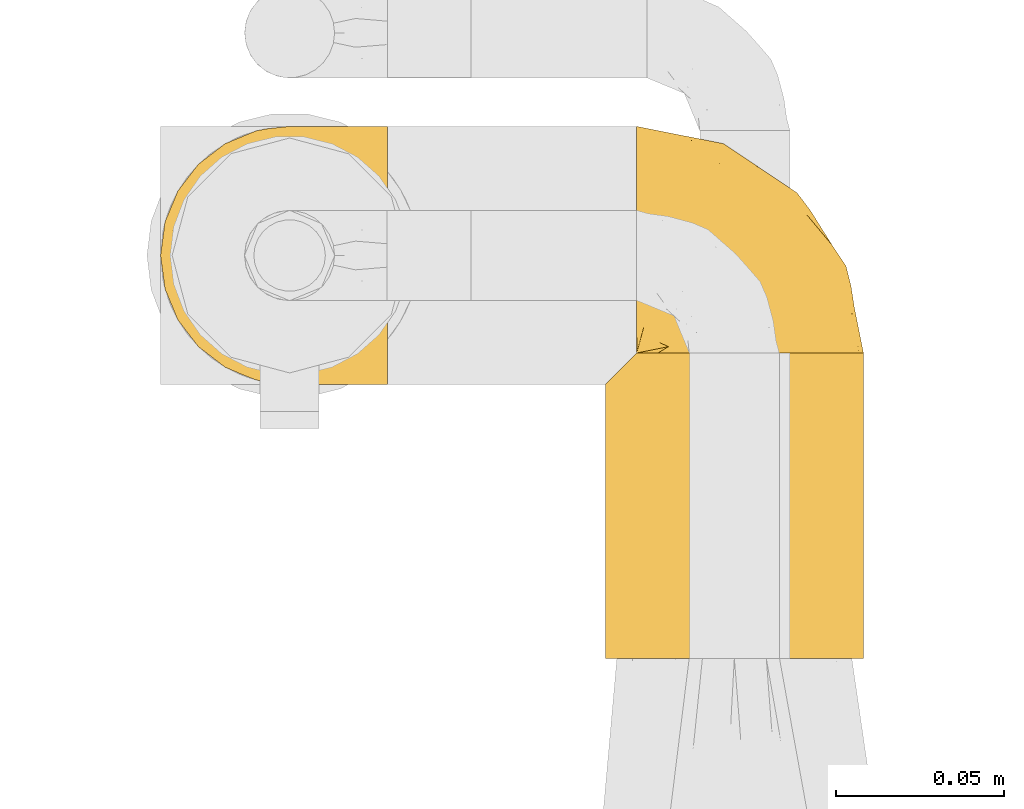
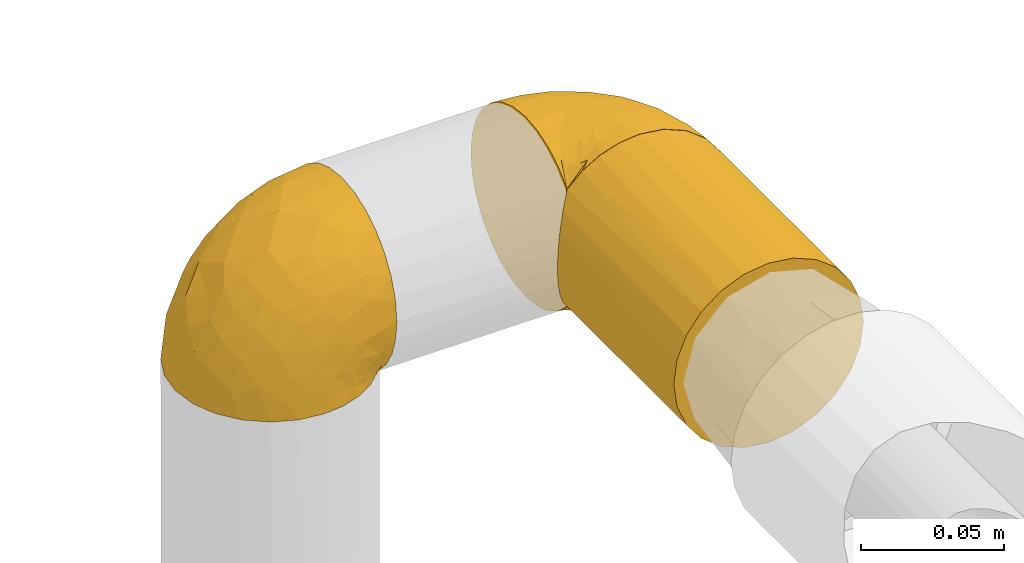
# One storey, part 66 of 827: 3 coverings.
"""IFC2X3 building model written with IfcOpenShell, lengths in millimetres."""

from ifc_helpers import new_model, entity, si_unit, converted_unit, derived_unit, direction, frame, origin, place, context, subcontext, project, spatial, faceted_brep, element, save


model = new_model("IFC2X3")

# Units and contexts
model_context = context("Model", 3, precision=0.01, world=origin(), true_north=direction((6.12303176911189e-17, 1.0)))
body_context = subcontext(model_context, "Body", "Model", "MODEL_VIEW")
ifc_project = project(units=[si_unit("LENGTHUNIT", "METRE", prefix="MILLI"), si_unit("AREAUNIT", "SQUARE_METRE"), si_unit("VOLUMEUNIT", "CUBIC_METRE"), converted_unit("PLANEANGLEUNIT", "DEGREE", entity("IfcRatioMeasure", 0.0174532925199433), si_unit("PLANEANGLEUNIT", "RADIAN"), dimensions=[0, 0, 0, 0, 0, 0, 0]), si_unit("MASSUNIT", "GRAM", prefix="KILO"), derived_unit("MASSDENSITYUNIT", [(si_unit("MASSUNIT", "GRAM", prefix="KILO"), 1), (si_unit("LENGTHUNIT", "METRE"), -3)]), derived_unit("MOMENTOFINERTIAUNIT", [(si_unit("LENGTHUNIT", "METRE"), 4)]), si_unit("TIMEUNIT", "SECOND"), si_unit("FREQUENCYUNIT", "HERTZ"), si_unit("THERMODYNAMICTEMPERATUREUNIT", "DEGREE_CELSIUS"), derived_unit("THERMALTRANSMITTANCEUNIT", [(si_unit("MASSUNIT", "GRAM", prefix="KILO"), 1), (si_unit("THERMODYNAMICTEMPERATUREUNIT", "KELVIN"), -1), (si_unit("TIMEUNIT", "SECOND"), -3)]), derived_unit("VOLUMETRICFLOWRATEUNIT", [(si_unit("LENGTHUNIT", "METRE"), 3), (si_unit("TIMEUNIT", "SECOND"), -1)]), derived_unit("MASSFLOWRATEUNIT", [(si_unit("MASSUNIT", "GRAM", prefix="KILO"), 1), (si_unit("TIMEUNIT", "SECOND"), -1)]), derived_unit("ROTATIONALFREQUENCYUNIT", [(si_unit("TIMEUNIT", "SECOND"), -1)]), si_unit("ELECTRICCURRENTUNIT", "AMPERE"), si_unit("ELECTRICVOLTAGEUNIT", "VOLT"), si_unit("POWERUNIT", "WATT"), si_unit("FORCEUNIT", "NEWTON", prefix="KILO"), si_unit("ILLUMINANCEUNIT", "LUX"), si_unit("LUMINOUSFLUXUNIT", "LUMEN"), si_unit("LUMINOUSINTENSITYUNIT", "CANDELA"), derived_unit("USERDEFINED", [(si_unit("MASSUNIT", "GRAM", prefix="KILO"), -1), (si_unit("LENGTHUNIT", "METRE"), -2), (si_unit("TIMEUNIT", "SECOND"), 3), (si_unit("LUMINOUSFLUXUNIT", "LUMEN"), 1)]), derived_unit("LINEARVELOCITYUNIT", [(si_unit("LENGTHUNIT", "METRE"), 1), (si_unit("TIMEUNIT", "SECOND"), -1)]), si_unit("PRESSUREUNIT", "PASCAL"), derived_unit("USERDEFINED", [(si_unit("LENGTHUNIT", "METRE"), -2), (si_unit("MASSUNIT", "GRAM", prefix="KILO"), 1), (si_unit("TIMEUNIT", "SECOND"), -2)]), derived_unit("LINEARFORCEUNIT", [(si_unit("MASSUNIT", "GRAM", prefix="KILO"), 1), (si_unit("LENGTHUNIT", "METRE"), 1), (si_unit("TIMEUNIT", "SECOND"), -2), (si_unit("LENGTHUNIT", "METRE"), -1)]), derived_unit("PLANARFORCEUNIT", [(si_unit("MASSUNIT", "GRAM", prefix="KILO"), 1), (si_unit("LENGTHUNIT", "METRE"), 1), (si_unit("TIMEUNIT", "SECOND"), -2), (si_unit("LENGTHUNIT", "METRE"), -2)])], contexts=[model_context])

# Site, building, storey
site_placement = place(None, origin())
site = spatial("IfcSite", under=ifc_project, at=site_placement, CompositionType="ELEMENT")
building_placement = place(site_placement, origin())
building = spatial("IfcBuilding", under=site, at=building_placement, CompositionType="ELEMENT")
storey_placement = place(building_placement, frame((0.0, 0.0, 28200.0)))
storey = spatial("IfcBuildingStorey", under=building, at=storey_placement, Name="08", CompositionType="ELEMENT", Elevation=28200.0)

# Coverings
covering_1_placement = place(storey_placement, frame((15026.93, 12139.38, 1515.05)))
element("IfcCovering", 1, at=covering_1_placement, inside=storey, Name=":ADSK_", ObjectType=":ADSK_", PredefinedType="INSULATION", context=body_context, shape_type="Brep", body=[
    faceted_brep([(69.15, 74.68, 47.38), (69.15, 70.1, 54.67), (69.15, 64.01, 60.76), (69.15, 56.72, 65.34), (69.15, 48.6, 68.18), (69.15, 40.05, 69.15), (69.15, 31.49, 68.18), (69.15, 23.36, 65.34), (69.15, 16.07, 60.75), (69.15, 9.98, 54.66), (69.15, 5.4, 47.37), (69.15, 2.56, 39.25), (69.15, 1.6, 30.7), (69.15, 2.46, 22.6), (69.15, 5.01, 14.86), (69.15, 9.13, 7.84), (69.15, 14.62, 1.85), (69.15, 16.82, 1.85), (69.15, 18.56, 1.85), (69.15, 20.52, 1.85), (69.15, 22.49, 1.85), (69.15, 24.46, 1.85), (69.15, 26.42, 1.85), (69.15, 28.39, 1.85), (69.15, 30.36, 1.85), (69.15, 32.55, 1.85), (69.15, 34.75, 1.85), (69.15, 36.94, 1.85), (69.15, 39.13, 1.85), (69.15, 41.33, 1.85), (69.15, 43.52, 1.85), (69.15, 45.72, 1.85), (69.15, 47.91, 1.85), (69.15, 50.11, 1.85), (69.15, 52.3, 1.85), (69.15, 54.49, 1.85), (69.15, 56.69, 1.85), (69.15, 58.88, 1.85), (69.15, 61.08, 1.85), (69.15, 63.27, 1.85), (69.15, 65.47, 1.85), (69.15, 70.97, 7.85), (69.15, 75.09, 14.88), (69.15, 77.64, 22.61), (69.15, 78.5, 30.7), (69.15, 77.53, 39.26), (68.89, 14.62, 1.6), (62.89, 9.12, 1.6), (55.87, 5.0, 1.6), (48.14, 2.46, 1.6), (40.05, 1.6, 1.6), (30.09, 2.91, 1.6), (20.82, 6.75, 1.6), (12.86, 12.86, 1.6), (6.75, 20.82, 1.6), (2.91, 30.09, 1.6), (1.6, 40.05, 1.6), (2.91, 50.0, 1.6), (6.75, 59.27, 1.6), (12.86, 67.23, 1.6), (20.82, 73.34, 1.6), (30.09, 77.19, 1.6), (40.05, 78.5, 1.6), (48.14, 77.63, 1.6), (55.87, 75.09, 1.6), (62.89, 70.97, 1.6), (68.89, 65.47, 1.6), (68.89, 63.27, 1.6), (68.89, 62.29, 1.6), (68.89, 60.7, 1.6), (68.89, 59.11, 1.6), (68.89, 57.52, 1.6), (68.89, 55.93, 1.6), (68.89, 54.34, 1.6), (68.89, 52.76, 1.6), (68.89, 51.17, 1.6), (68.89, 49.58, 1.6), (68.89, 47.99, 1.6), (68.89, 46.4, 1.6), (68.89, 44.81, 1.6), (68.89, 43.22, 1.6), (68.89, 41.63, 1.6), (68.89, 40.05, 1.6), (68.89, 38.46, 1.6), (68.89, 36.87, 1.6), (68.89, 35.28, 1.6), (68.89, 33.69, 1.6), (68.89, 32.1, 1.6), (68.89, 30.51, 1.6), (68.89, 28.92, 1.6), (68.89, 27.33, 1.6), (68.89, 25.37, 1.6), (68.89, 23.4, 1.6), (68.89, 21.21, 1.6), (68.89, 19.01, 1.6), (68.89, 16.82, 1.6), (68.97, 42.32, 1.78), (68.96, 44.02, 1.77), (68.97, 47.13, 1.78), (68.97, 48.74, 1.77), (68.98, 23.57, 1.79), (68.97, 25.13, 1.78), (68.96, 61.34, 1.76), (68.96, 22.02, 1.77), (68.96, 29.72, 1.77), (68.96, 56.73, 1.76), (68.96, 55.14, 1.77), (68.96, 37.66, 1.77), (69.0, 64.12, 1.8), (68.96, 28.13, 1.76), (68.96, 26.62, 1.77), (68.97, 31.46, 1.78), (68.96, 16.16, 1.77), (68.96, 39.16, 1.77), (68.96, 50.37, 1.76), (68.97, 17.69, 1.77), (68.97, 19.17, 1.78), (68.97, 62.78, 1.77), (68.96, 58.35, 1.77), (68.96, 45.53, 1.77), (68.97, 59.91, 1.78), (68.97, 65.47, 1.77), (69.02, 65.47, 1.8), (69.08, 65.47, 1.82), (68.97, 14.62, 1.77), (68.94, 14.62, 1.72), (68.92, 14.62, 1.66), (68.96, 20.59, 1.76), (68.96, 32.99, 1.77), (68.95, 34.48, 1.76), (68.96, 51.91, 1.77), (68.92, 65.47, 1.66), (68.94, 65.47, 1.72), (68.98, 53.48, 1.78), (69.08, 14.62, 1.82), (69.02, 14.62, 1.8), (68.96, 40.77, 1.77), (68.97, 35.97, 1.78), (61.33, 7.84, 3.72), (53.1, 3.53, 7.41), (63.33, 8.32, 6.13), (49.27, 1.6, 21.47), (55.53, 2.19, 19.34), (54.6, 1.6, 26.8), (41.99, 1.6, 8.87), (57.07, 4.57, 9.2), (57.95, 3.96, 12.79), (51.56, 2.28, 14.62), (41.58, 1.6, 7.34), (61.7, 7.69, 5.33), (63.33, 3.53, 17.64), (65.0, 8.32, 7.7), (67.02, 7.84, 9.41), (61.87, 1.6, 28.75), (43.94, 1.6, 16.15), (61.21, 4.34, 14.14), (63.4, 1.6, 29.16), (33.11, 29.63, 57.02), (52.82, 27.34, 64.92), (43.3, 40.05, 64.0), (33.73, 2.39, 11.92), (36.52, 2.43, 19.16), (24.87, 9.07, 28.65), (14.17, 16.64, 24.62), (18.43, 9.54, 15.19), (28.67, 4.52, 18.36), (26.0, 4.52, 9.2), (49.25, 7.49, 46.98), (59.72, 7.49, 50.24), (55.1, 12.85, 56.1), (44.72, 2.35, 28.97), (34.15, 22.67, 54.46), (5.25, 32.9, 21.34), (6.75, 25.33, 18.4), (55.54, 40.05, 66.44), (10.47, 16.64, 12.07), (25.49, 19.99, 45.49), (35.53, 16.37, 50.57), (48.22, 3.26, 36.04), (58.71, 3.75, 42.07), (57.42, 19.58, 62.12), (34.84, 7.5, 37.37), (36.87, 4.04, 29.39), (45.01, 13.94, 53.59), (44.4, 19.58, 58.06), (23.96, 28.21, 49.27), (11.2, 24.75, 29.63), (10.56, 31.42, 33.21), (16.81, 26.2, 40.1), (17.38, 33.36, 44.08), (21.38, 40.05, 49.36), (32.34, 40.05, 56.68), (4.3, 40.05, 15.2), (20.65, 16.14, 35.57), (29.66, 12.85, 41.7), (39.6, 10.47, 46.4), (42.55, 6.49, 41.41), (6.74, 40.05, 27.45), (14.06, 40.05, 38.4), (26.84, 75.57, 12.99), (5.28, 47.37, 21.33), (18.52, 52.91, 42.89), (33.13, 50.46, 57.04), (55.1, 67.23, 56.11), (57.43, 60.5, 62.13), (20.72, 70.55, 21.89), (11.46, 63.45, 16.62), (17.69, 62.61, 32.9), (49.26, 72.6, 46.99), (59.73, 72.6, 50.25), (58.71, 76.34, 42.08), (29.72, 59.34, 49.92), (35.35, 77.76, 15.6), (43.94, 78.5, 16.15), (41.99, 78.5, 8.87), (63.4, 78.5, 29.16), (4.93, 53.16, 13.16), (17.46, 70.55, 10.83), (10.94, 48.88, 33.8), (8.92, 54.76, 25.02), (52.83, 52.74, 64.92), (29.34, 71.93, 32.83), (30.26, 75.79, 20.56), (44.4, 60.5, 58.07), (39.06, 77.86, 21.46), (43.06, 77.64, 28.1), (54.6, 78.5, 26.8), (49.27, 78.5, 21.47), (42.69, 67.23, 51.29), (48.2, 76.82, 36.04), (61.87, 78.5, 28.75), (33.44, 77.8, 8.45), (29.67, 67.23, 41.73), (38.5, 73.21, 39.27), (23.35, 67.66, 33.56), (34.97, 75.99, 27.29), (53.1, 76.57, 7.41), (59.68, 73.21, 3.51), (62.19, 71.93, 4.68), (64.11, 71.07, 5.52), (57.97, 75.09, 8.75), (57.95, 76.13, 12.79), (63.33, 76.57, 17.65), (51.77, 77.69, 13.9), (67.02, 72.26, 9.42), (64.98, 71.77, 7.68), (55.53, 77.9, 19.33), (61.22, 75.75, 14.13)], [[[0, 1, 2, 3, 4, 5, 6, 7, 8, 9, 10, 11, 12, 13, 14, 15, 16, 17, 18, 19, 20, 21, 22, 23, 24, 25, 26, 27, 28, 29, 30, 31, 32, 33, 34, 35, 36, 37, 38, 39, 40, 41, 42, 43, 44, 45]], [[46, 47, 48, 49, 50, 51, 52, 53, 54, 55, 56, 57, 58, 59, 60, 61, 62, 63, 64, 65, 66, 67, 68, 69, 70, 71, 72, 73, 74, 75, 76, 77, 78, 79, 80, 81, 82, 83, 84, 85, 86, 87, 88, 89, 90, 91, 92, 93, 94, 95]], [[96, 97, 30]], [[98, 77, 99]], [[100, 101, 21]], [[69, 68, 102]], [[20, 19, 103]], [[24, 23, 104]], [[20, 103, 100]], [[72, 105, 106]], [[84, 83, 107]], [[89, 88, 104]], [[108, 67, 66]], [[109, 110, 90]], [[111, 25, 24]], [[112, 17, 16]], [[82, 113, 83]], [[109, 23, 22]], [[114, 76, 75]], [[105, 36, 106]], [[104, 111, 24]], [[18, 115, 116]], [[97, 96, 80]], [[67, 108, 117]], [[105, 71, 118]], [[31, 97, 119]], [[102, 120, 69]], [[108, 121, 122, 123, 40]], [[112, 95, 115]], [[17, 115, 18]], [[94, 116, 115]], [[117, 68, 67]], [[38, 117, 39]], [[112, 124, 125, 126, 46]], [[17, 112, 115]], [[70, 120, 118]], [[39, 117, 108]], [[120, 38, 37]], [[120, 37, 118]], [[120, 70, 69]], [[116, 94, 127]], [[128, 86, 129]], [[117, 38, 102]], [[74, 130, 75]], [[99, 33, 32]], [[115, 95, 94]], [[39, 108, 40]], [[108, 66, 131, 132, 121]], [[105, 72, 71]], [[118, 37, 36]], [[71, 70, 118]], [[35, 106, 36]], [[36, 105, 118]], [[35, 133, 106]], [[74, 73, 133]], [[106, 133, 73]], [[99, 114, 33]], [[133, 35, 34]], [[73, 72, 106]], [[95, 112, 46]], [[112, 16, 134, 135, 124]], [[130, 114, 75]], [[99, 76, 114]], [[114, 130, 33]], [[34, 33, 130]], [[78, 77, 98]], [[98, 119, 78]], [[130, 133, 34]], [[133, 130, 74]], [[79, 97, 80]], [[98, 99, 32]], [[98, 32, 31]], [[77, 76, 99]], [[97, 79, 119]], [[136, 96, 29]], [[30, 97, 31]], [[136, 29, 28]], [[81, 80, 96]], [[29, 96, 30]], [[31, 119, 98]], [[119, 79, 78]], [[96, 136, 81]], [[82, 81, 136]], [[113, 107, 83]], [[84, 107, 137]], [[107, 27, 137]], [[113, 28, 107]], [[27, 107, 28]], [[85, 84, 137]], [[137, 27, 26]], [[113, 136, 28]], [[136, 113, 82]], [[109, 89, 104]], [[86, 85, 129]], [[89, 109, 90]], [[111, 87, 128]], [[26, 129, 137]], [[88, 111, 104]], [[25, 111, 128]], [[22, 110, 109]], [[23, 109, 104]], [[110, 91, 90]], [[100, 92, 101]], [[110, 22, 101]], [[91, 110, 101]], [[116, 19, 18]], [[111, 88, 87]], [[127, 103, 19]], [[25, 128, 26]], [[86, 128, 87]], [[128, 129, 26]], [[137, 129, 85]], [[120, 102, 38]], [[117, 102, 68]], [[91, 101, 92]], [[21, 101, 22]], [[93, 92, 103]], [[100, 21, 20]], [[100, 103, 92]], [[127, 93, 103]], [[93, 127, 94]], [[116, 127, 19]], [[126, 138, 47]], [[48, 138, 139]], [[140, 125, 124]], [[141, 142, 143]], [[144, 49, 139]], [[145, 140, 146]], [[48, 139, 49]], [[139, 145, 147]], [[49, 144, 148, 50]], [[126, 125, 149]], [[14, 13, 150]], [[151, 146, 140]], [[149, 140, 145]], [[152, 151, 135]], [[152, 14, 150]], [[16, 15, 134]], [[13, 153, 150]], [[124, 151, 140]], [[141, 147, 142]], [[14, 152, 15]], [[15, 152, 134]], [[47, 46, 126]], [[139, 154, 144]], [[138, 48, 47]], [[125, 140, 149]], [[135, 134, 152]], [[146, 155, 142]], [[145, 146, 147]], [[149, 139, 138]], [[147, 141, 154]], [[147, 146, 142]], [[139, 147, 154]], [[139, 149, 145]], [[149, 138, 126]], [[155, 146, 151]], [[150, 143, 142]], [[152, 155, 151]], [[150, 142, 155]], [[13, 12, 156, 153]], [[153, 143, 150]], [[152, 150, 155]], [[151, 124, 135]], [[157, 158, 159]], [[160, 154, 161]], [[162, 163, 164]], [[165, 166, 160]], [[167, 168, 169]], [[141, 170, 161]], [[156, 12, 11]], [[158, 157, 171]], [[172, 55, 173]], [[158, 6, 174]], [[175, 54, 53]], [[52, 166, 164]], [[52, 164, 53]], [[54, 175, 173]], [[166, 52, 51]], [[176, 177, 171]], [[178, 143, 179]], [[156, 11, 179]], [[8, 7, 180]], [[169, 9, 8]], [[179, 143, 153, 156]], [[179, 11, 10]], [[168, 179, 10]], [[181, 162, 182]], [[179, 167, 178]], [[183, 184, 177]], [[183, 169, 184]], [[176, 171, 185]], [[172, 186, 187]], [[158, 7, 6]], [[159, 158, 174]], [[184, 180, 158]], [[54, 173, 55]], [[180, 169, 8]], [[188, 189, 187]], [[9, 168, 10]], [[186, 188, 187]], [[190, 157, 159, 191]], [[55, 172, 192]], [[176, 193, 194]], [[161, 170, 182]], [[162, 164, 165]], [[175, 164, 163]], [[51, 50, 148]], [[167, 195, 196]], [[178, 182, 170]], [[6, 5, 174]], [[158, 180, 7]], [[169, 180, 184]], [[169, 168, 9]], [[179, 168, 167]], [[182, 162, 165]], [[162, 194, 193]], [[161, 165, 160]], [[195, 181, 196]], [[192, 172, 197]], [[192, 56, 55]], [[189, 190, 198]], [[198, 197, 187]], [[172, 187, 197]], [[185, 189, 188]], [[198, 187, 189]], [[186, 172, 173]], [[173, 163, 186]], [[193, 186, 163]], [[176, 185, 188]], [[185, 157, 190]], [[188, 186, 193]], [[177, 176, 194]], [[188, 193, 176]], [[162, 193, 163]], [[195, 177, 194]], [[171, 177, 184]], [[181, 195, 194]], [[183, 167, 169]], [[162, 181, 194]], [[196, 182, 178]], [[158, 171, 184]], [[171, 157, 185]], [[177, 195, 183]], [[167, 183, 195]], [[182, 196, 181]], [[178, 170, 143]], [[178, 167, 196]], [[164, 175, 53]], [[173, 175, 163]], [[160, 51, 148]], [[164, 166, 165]], [[51, 160, 166]], [[160, 148, 144, 154]], [[141, 161, 154]], [[182, 165, 161]], [[190, 189, 185]], [[143, 170, 141]], [[60, 199, 61]], [[197, 200, 192]], [[201, 190, 202]], [[200, 57, 192]], [[203, 204, 2]], [[205, 206, 207]], [[208, 209, 210]], [[211, 207, 201]], [[212, 213, 214]], [[45, 215, 210]], [[216, 206, 58]], [[45, 44, 215]], [[59, 217, 60]], [[60, 217, 199]], [[0, 45, 210]], [[218, 201, 219]], [[202, 159, 220]], [[205, 221, 222]], [[223, 204, 203]], [[1, 203, 2]], [[57, 200, 216]], [[220, 3, 204]], [[220, 174, 4]], [[1, 0, 209]], [[212, 224, 213]], [[225, 226, 227]], [[228, 223, 203]], [[208, 210, 229]], [[210, 226, 229]], [[3, 220, 4]], [[58, 206, 59]], [[209, 203, 1]], [[202, 220, 223]], [[228, 203, 208]], [[202, 211, 201]], [[3, 2, 204]], [[202, 190, 191, 159]], [[210, 215, 230, 226]], [[199, 212, 231]], [[232, 233, 221]], [[233, 208, 229]], [[207, 206, 219]], [[217, 206, 205]], [[227, 224, 225]], [[233, 232, 228]], [[201, 207, 219]], [[234, 232, 221]], [[218, 219, 200]], [[202, 223, 211]], [[174, 220, 159]], [[174, 5, 4]], [[61, 231, 62]], [[220, 204, 223]], [[210, 209, 0]], [[203, 209, 208]], [[225, 233, 229]], [[224, 227, 213]], [[221, 233, 235]], [[57, 56, 192]], [[198, 218, 197]], [[200, 219, 216]], [[201, 198, 190]], [[197, 218, 200]], [[198, 201, 218]], [[206, 216, 219]], [[58, 57, 216]], [[231, 212, 214]], [[222, 212, 199]], [[228, 211, 223]], [[207, 211, 232]], [[62, 231, 214]], [[199, 231, 61]], [[233, 228, 208]], [[211, 228, 232]], [[222, 221, 235]], [[234, 205, 207]], [[206, 217, 59]], [[199, 217, 205]], [[205, 222, 199]], [[224, 222, 235]], [[222, 224, 212]], [[224, 235, 225]], [[233, 225, 235]], [[226, 225, 229]], [[205, 234, 221]], [[207, 232, 234]], [[63, 214, 236]], [[214, 213, 236]], [[214, 63, 62]], [[237, 236, 238]], [[238, 132, 131]], [[236, 237, 64]], [[239, 240, 241]], [[63, 236, 64]], [[131, 66, 65]], [[237, 131, 65]], [[242, 230, 43]], [[237, 65, 64]], [[239, 121, 132]], [[42, 242, 43]], [[241, 240, 243]], [[41, 123, 244]], [[43, 230, 215, 44]], [[244, 122, 245]], [[227, 246, 243]], [[245, 241, 247]], [[121, 239, 245]], [[41, 40, 123]], [[132, 238, 239]], [[244, 42, 41]], [[131, 237, 238]], [[240, 239, 238]], [[245, 239, 241]], [[247, 241, 246]], [[247, 244, 245]], [[238, 236, 240]], [[243, 236, 213]], [[236, 243, 240]], [[246, 241, 243]], [[243, 213, 227]], [[226, 242, 246]], [[227, 226, 246]], [[246, 242, 247]], [[244, 247, 242]], [[242, 226, 230]], [[42, 244, 242]], [[122, 244, 123]], [[122, 121, 245]]]),
])
covering_2_placement = place(storey_placement, frame((15159.48, 12059.42, 1505.75)))
element("IfcCovering", 2, at=covering_2_placement, inside=storey, Name=":ADSK_", ObjectType=":ADSK_", PredefinedType="INSULATION", context=body_context, shape_type="Brep", body=[
    faceted_brep([(31.79, 90.9, 77.51), (40.0, 90.9, 78.4), (49.93, 90.9, 77.09), (59.2, 90.9, 73.25), (67.15, 90.9, 67.15), (73.25, 90.9, 59.2), (77.09, 90.9, 49.93), (78.4, 90.9, 40.0), (77.09, 90.9, 30.06), (73.25, 90.9, 20.8), (67.15, 90.9, 12.84), (59.2, 90.9, 6.74), (49.93, 90.9, 2.9), (40.0, 90.9, 1.6), (31.79, 90.9, 2.48), (23.98, 90.9, 5.09), (16.91, 90.9, 9.31), (10.9, 90.9, 14.94), (10.9, 90.9, 65.05), (16.91, 90.9, 70.68), (23.98, 90.9, 74.9), (20.8, 0.0, 73.25), (12.84, 0.0, 67.15), (6.74, 0.0, 59.2), (2.9, 0.0, 49.93), (1.6, 0.0, 40.0), (2.9, 0.0, 30.06), (6.74, 0.0, 20.8), (12.84, 0.0, 12.84), (20.8, 0.0, 6.74), (30.06, 0.0, 2.9), (40.0, 0.0, 1.6), (49.93, 0.0, 2.9), (59.2, 0.0, 6.74), (67.15, 0.0, 12.84), (73.25, 0.0, 20.8), (77.09, 0.0, 30.06), (78.4, 0.0, 40.0), (77.09, 0.0, 49.93), (73.25, 0.0, 59.2), (67.15, 0.0, 67.15), (59.2, 0.0, 73.25), (49.93, 0.0, 77.09), (40.0, 0.0, 78.4), (30.06, 0.0, 77.09), (4.0, 84.0, 26.63), (2.2, 82.2, 33.21), (1.6, 81.6, 40.0), (6.92, 86.93, 20.48), (2.2, 82.2, 46.78), (4.0, 84.0, 53.36), (6.92, 86.93, 59.51)], [[[0, 1, 2, 3, 4, 5, 6, 7, 8, 9, 10, 11, 12, 13, 14, 15, 16, 17, 18, 19, 20]], [[21, 22, 23, 24, 25, 26, 27, 28, 29, 30, 31, 32, 33, 34, 35, 36, 37, 38, 39, 40, 41, 42, 43, 44]], [[36, 35, 9, 8]], [[37, 36, 8, 7]], [[35, 34, 10, 9]], [[12, 11, 33, 32]], [[13, 12, 32, 31]], [[34, 33, 11, 10]], [[14, 31, 30]], [[15, 30, 29]], [[16, 29, 28]], [[13, 31, 14]], [[14, 30, 15]], [[29, 16, 15]], [[28, 17, 16]], [[45, 27, 26]], [[26, 25, 46]], [[47, 46, 25]], [[48, 17, 27]], [[46, 45, 26]], [[48, 27, 45]], [[27, 17, 28]], [[49, 47, 25]], [[49, 25, 24]], [[50, 24, 23]], [[50, 49, 24]], [[18, 51, 23]], [[50, 23, 51]], [[23, 22, 18]], [[19, 22, 21]], [[20, 21, 44]], [[0, 44, 43]], [[19, 21, 20]], [[20, 44, 0]], [[43, 1, 0]], [[22, 19, 18]], [[2, 1, 43, 42]], [[3, 2, 42, 41]], [[41, 40, 4, 3]], [[6, 5, 39, 38]], [[7, 6, 38, 37]], [[40, 39, 5, 4]], [[46, 47, 49, 50, 51, 18, 17, 48, 45]]]),
])
covering_3_placement = place(storey_placement, frame((15168.78, 12148.73, 1505.7)))
element("IfcCovering", 3, at=covering_3_placement, inside=storey, Name=":ADSK_", ObjectType=":ADSK_", PredefinedType="INSULATION", context=body_context, shape_type="Brep", body=[
    faceted_brep([(1.6, 47.38, 74.68), (1.6, 54.67, 70.1), (1.6, 60.76, 64.01), (1.6, 65.34, 56.72), (1.6, 68.18, 48.6), (1.6, 69.15, 40.05), (1.6, 68.18, 31.49), (1.6, 65.33, 23.36), (1.6, 60.75, 16.07), (1.6, 54.66, 9.98), (1.6, 47.37, 5.4), (1.6, 39.25, 2.56), (1.6, 30.7, 1.6), (1.6, 22.59, 2.46), (1.6, 14.86, 5.01), (1.6, 7.84, 9.13), (1.6, 1.85, 14.62), (1.6, 1.85, 16.82), (1.6, 1.85, 18.56), (1.6, 1.85, 20.52), (1.6, 1.85, 22.49), (1.6, 1.85, 24.46), (1.6, 1.85, 26.42), (1.6, 1.85, 28.39), (1.6, 1.85, 30.36), (1.6, 1.85, 32.55), (1.6, 1.85, 34.75), (1.6, 1.85, 36.94), (1.6, 1.85, 39.13), (1.6, 1.85, 41.33), (1.6, 1.85, 43.52), (1.6, 1.85, 45.72), (1.6, 1.85, 47.91), (1.6, 1.85, 50.11), (1.6, 1.85, 52.3), (1.6, 1.85, 54.49), (1.6, 1.85, 56.69), (1.6, 1.85, 58.88), (1.6, 1.85, 61.08), (1.6, 1.85, 63.27), (1.6, 1.85, 65.47), (1.6, 7.85, 70.97), (1.6, 14.88, 75.09), (1.6, 22.61, 77.64), (1.6, 30.7, 78.5), (1.6, 39.26, 77.53), (1.85, 1.6, 14.62), (7.85, 1.6, 9.12), (14.87, 1.6, 5.0), (22.6, 1.6, 2.46), (30.7, 1.6, 1.6), (40.65, 1.6, 2.91), (49.92, 1.6, 6.75), (57.88, 1.6, 12.86), (63.99, 1.6, 20.82), (67.84, 1.6, 30.09), (69.15, 1.6, 40.05), (67.84, 1.6, 50.0), (63.99, 1.6, 59.27), (57.88, 1.6, 67.23), (49.92, 1.6, 73.34), (40.65, 1.6, 77.19), (30.7, 1.6, 78.5), (22.6, 1.6, 77.63), (14.87, 1.6, 75.09), (7.85, 1.6, 70.97), (1.85, 1.6, 65.47), (1.85, 1.6, 63.27), (1.85, 1.6, 62.29), (1.85, 1.6, 60.7), (1.85, 1.6, 59.11), (1.85, 1.6, 57.52), (1.85, 1.6, 55.93), (1.85, 1.6, 54.34), (1.85, 1.6, 52.76), (1.85, 1.6, 51.17), (1.85, 1.6, 49.58), (1.85, 1.6, 47.99), (1.85, 1.6, 46.4), (1.85, 1.6, 44.81), (1.85, 1.6, 43.22), (1.85, 1.6, 41.63), (1.85, 1.6, 40.05), (1.85, 1.6, 38.46), (1.85, 1.6, 36.87), (1.85, 1.6, 35.28), (1.85, 1.6, 33.69), (1.85, 1.6, 32.1), (1.85, 1.6, 30.51), (1.85, 1.6, 28.92), (1.85, 1.6, 27.33), (1.85, 1.6, 25.37), (1.85, 1.6, 23.4), (1.85, 1.6, 21.21), (1.85, 1.6, 19.01), (1.85, 1.6, 16.82), (1.77, 1.78, 42.32), (1.78, 1.77, 44.02), (1.77, 1.78, 47.13), (1.77, 1.77, 48.74), (1.76, 1.79, 23.57), (1.77, 1.78, 25.13), (1.79, 1.76, 61.34), (1.78, 1.77, 22.02), (1.78, 1.77, 29.72), (1.78, 1.76, 56.73), (1.78, 1.77, 55.14), (1.78, 1.77, 37.66), (1.74, 1.8, 64.12), (1.78, 1.76, 28.13), (1.78, 1.77, 26.62), (1.77, 1.78, 31.46), (1.78, 1.77, 16.16), (1.78, 1.77, 39.16), (1.78, 1.76, 50.37), (1.77, 1.77, 17.69), (1.77, 1.78, 19.17), (1.77, 1.77, 62.78), (1.78, 1.77, 58.35), (1.78, 1.77, 45.53), (1.77, 1.78, 59.91), (1.77, 1.77, 65.47), (1.72, 1.8, 65.47), (1.66, 1.82, 65.47), (1.77, 1.77, 14.62), (1.8, 1.72, 14.62), (1.82, 1.66, 14.62), (1.79, 1.76, 20.59), (1.78, 1.77, 32.99), (1.79, 1.76, 34.48), (1.78, 1.77, 51.91), (1.82, 1.66, 65.47), (1.8, 1.72, 65.47), (1.76, 1.78, 53.48), (1.66, 1.82, 14.62), (1.72, 1.8, 14.62), (1.78, 1.77, 40.77), (1.77, 1.78, 35.97), (9.41, 3.72, 7.84), (17.65, 7.41, 3.53), (7.41, 6.13, 8.32), (15.21, 19.34, 2.19), (7.41, 17.64, 3.53), (16.15, 26.8, 1.6), (28.75, 8.87, 1.6), (13.67, 9.2, 4.57), (12.79, 12.79, 3.96), (19.18, 14.62, 2.28), (29.16, 7.34, 1.6), (9.04, 5.33, 7.69), (5.74, 7.7, 8.32), (3.72, 9.41, 7.84), (8.87, 28.75, 1.6), (21.47, 21.47, 1.6), (26.8, 16.15, 1.6), (9.53, 14.14, 4.34), (7.34, 29.16, 1.6), (37.63, 57.02, 29.63), (17.92, 64.92, 27.34), (27.45, 64.0, 40.05), (37.01, 11.92, 2.39), (34.22, 19.16, 2.43), (45.87, 28.65, 9.07), (56.57, 24.62, 16.64), (52.31, 15.19, 9.54), (42.07, 18.36, 4.52), (44.74, 9.2, 4.52), (21.49, 46.98, 7.49), (11.02, 50.24, 7.49), (15.64, 56.1, 12.85), (26.02, 28.97, 2.35), (36.59, 54.46, 22.66), (65.49, 21.34, 32.9), (63.99, 18.4, 25.33), (15.2, 66.44, 40.05), (60.27, 12.07, 16.64), (45.25, 45.49, 19.99), (35.21, 50.57, 16.37), (22.52, 36.04, 3.26), (12.03, 42.07, 3.75), (13.32, 62.12, 19.58), (35.9, 37.37, 7.5), (33.87, 29.39, 4.04), (25.73, 53.59, 13.94), (26.34, 58.06, 19.58), (46.78, 49.27, 28.21), (59.54, 29.63, 24.75), (60.18, 33.21, 31.42), (53.93, 40.1, 26.2), (53.36, 44.08, 33.36), (49.36, 49.36, 40.05), (38.4, 56.68, 40.05), (66.44, 15.2, 40.05), (50.09, 35.57, 16.14), (41.08, 41.7, 12.85), (31.14, 46.4, 10.47), (28.19, 41.41, 6.49), (64.0, 27.45, 40.05), (56.68, 38.4, 40.05), (43.9, 12.99, 75.57), (65.46, 21.33, 47.37), (52.22, 42.89, 52.91), (37.61, 57.04, 50.46), (15.64, 56.11, 67.23), (13.31, 62.13, 60.5), (50.02, 21.89, 70.55), (59.28, 16.62, 63.45), (53.05, 32.9, 62.61), (21.48, 46.99, 72.6), (11.01, 50.25, 72.6), (12.03, 42.08, 76.34), (41.02, 49.91, 59.34), (35.39, 15.6, 77.76), (26.8, 16.15, 78.5), (28.75, 8.87, 78.5), (7.34, 29.16, 78.5), (65.81, 13.16, 53.16), (53.28, 10.83, 70.55), (59.8, 33.8, 48.88), (61.82, 25.02, 54.76), (17.91, 64.92, 52.74), (41.4, 32.83, 71.93), (40.48, 20.56, 75.79), (26.34, 58.07, 60.5), (31.68, 21.46, 77.86), (27.68, 28.1, 77.64), (16.15, 26.8, 78.5), (21.47, 21.47, 78.5), (28.05, 51.29, 67.23), (22.54, 36.04, 76.82), (8.87, 28.75, 78.5), (37.3, 8.45, 77.8), (41.07, 41.73, 67.23), (32.24, 39.27, 73.2), (47.4, 33.56, 67.66), (35.77, 27.29, 75.99), (17.65, 7.41, 76.57), (11.06, 3.51, 73.21), (8.55, 4.68, 71.93), (6.63, 5.52, 71.07), (12.77, 8.75, 75.09), (12.79, 12.79, 76.13), (7.41, 17.65, 76.57), (18.97, 13.9, 77.69), (3.72, 9.42, 72.26), (5.76, 7.68, 71.77), (15.21, 19.33, 77.9), (9.52, 14.13, 75.75)], [[[0, 1, 2, 3, 4, 5, 6, 7, 8, 9, 10, 11, 12, 13, 14, 15, 16, 17, 18, 19, 20, 21, 22, 23, 24, 25, 26, 27, 28, 29, 30, 31, 32, 33, 34, 35, 36, 37, 38, 39, 40, 41, 42, 43, 44, 45]], [[46, 47, 48, 49, 50, 51, 52, 53, 54, 55, 56, 57, 58, 59, 60, 61, 62, 63, 64, 65, 66, 67, 68, 69, 70, 71, 72, 73, 74, 75, 76, 77, 78, 79, 80, 81, 82, 83, 84, 85, 86, 87, 88, 89, 90, 91, 92, 93, 94, 95]], [[96, 97, 30]], [[98, 77, 99]], [[100, 101, 21]], [[69, 68, 102]], [[20, 19, 103]], [[24, 23, 104]], [[20, 103, 100]], [[72, 105, 106]], [[84, 83, 107]], [[89, 88, 104]], [[108, 67, 66]], [[109, 110, 90]], [[111, 25, 24]], [[112, 17, 16]], [[82, 113, 83]], [[109, 23, 22]], [[114, 76, 75]], [[105, 36, 106]], [[104, 111, 24]], [[18, 115, 116]], [[97, 96, 80]], [[67, 108, 117]], [[105, 71, 118]], [[31, 97, 119]], [[102, 120, 69]], [[108, 121, 122, 123, 40]], [[112, 95, 115]], [[17, 115, 18]], [[94, 116, 115]], [[117, 68, 67]], [[38, 117, 39]], [[112, 124, 125, 126, 46]], [[17, 112, 115]], [[70, 120, 118]], [[39, 117, 108]], [[120, 38, 37]], [[120, 37, 118]], [[120, 70, 69]], [[116, 94, 127]], [[128, 86, 129]], [[117, 38, 102]], [[74, 130, 75]], [[99, 33, 32]], [[115, 95, 94]], [[39, 108, 40]], [[108, 66, 131, 132, 121]], [[105, 72, 71]], [[118, 37, 36]], [[71, 70, 118]], [[35, 106, 36]], [[36, 105, 118]], [[35, 133, 106]], [[74, 73, 133]], [[106, 133, 73]], [[99, 114, 33]], [[133, 35, 34]], [[73, 72, 106]], [[95, 112, 46]], [[112, 16, 134, 135, 124]], [[130, 114, 75]], [[99, 76, 114]], [[114, 130, 33]], [[34, 33, 130]], [[78, 77, 98]], [[98, 119, 78]], [[130, 133, 34]], [[133, 130, 74]], [[79, 97, 80]], [[98, 99, 32]], [[98, 32, 31]], [[77, 76, 99]], [[97, 79, 119]], [[136, 96, 29]], [[30, 97, 31]], [[136, 29, 28]], [[81, 80, 96]], [[29, 96, 30]], [[31, 119, 98]], [[119, 79, 78]], [[96, 136, 81]], [[82, 81, 136]], [[113, 107, 83]], [[84, 107, 137]], [[107, 27, 137]], [[113, 28, 107]], [[27, 107, 28]], [[85, 84, 137]], [[137, 27, 26]], [[113, 136, 28]], [[136, 113, 82]], [[109, 89, 104]], [[86, 85, 129]], [[89, 109, 90]], [[111, 87, 128]], [[26, 129, 137]], [[88, 111, 104]], [[25, 111, 128]], [[22, 110, 109]], [[23, 109, 104]], [[110, 91, 90]], [[100, 92, 101]], [[110, 22, 101]], [[91, 110, 101]], [[116, 19, 18]], [[111, 88, 87]], [[127, 103, 19]], [[25, 128, 26]], [[86, 128, 87]], [[128, 129, 26]], [[137, 129, 85]], [[120, 102, 38]], [[117, 102, 68]], [[91, 101, 92]], [[21, 101, 22]], [[93, 92, 103]], [[100, 21, 20]], [[100, 103, 92]], [[127, 93, 103]], [[93, 127, 94]], [[116, 127, 19]], [[126, 138, 47]], [[48, 138, 139]], [[140, 125, 124]], [[141, 142, 143]], [[144, 49, 139]], [[145, 140, 146]], [[48, 139, 49]], [[139, 145, 147]], [[49, 144, 148, 50]], [[126, 125, 149]], [[14, 13, 142]], [[150, 146, 140]], [[149, 140, 145]], [[151, 150, 135]], [[151, 14, 142]], [[16, 15, 134]], [[13, 152, 142]], [[124, 150, 140]], [[141, 143, 153]], [[14, 151, 15]], [[15, 151, 134]], [[47, 46, 126]], [[139, 154, 144]], [[138, 48, 47]], [[125, 140, 149]], [[135, 134, 151]], [[146, 155, 141]], [[145, 146, 147]], [[149, 139, 138]], [[147, 153, 154]], [[147, 146, 141]], [[139, 147, 154]], [[139, 149, 145]], [[149, 138, 126]], [[147, 141, 153]], [[146, 150, 155]], [[151, 155, 150]], [[142, 141, 155]], [[13, 12, 156, 152]], [[152, 143, 142]], [[151, 142, 155]], [[150, 124, 135]], [[157, 158, 159]], [[160, 154, 161]], [[162, 163, 164]], [[165, 166, 160]], [[167, 168, 169]], [[153, 170, 161]], [[156, 12, 11]], [[158, 157, 171]], [[172, 55, 173]], [[158, 6, 174]], [[175, 54, 53]], [[52, 166, 164]], [[52, 164, 53]], [[54, 175, 173]], [[166, 52, 51]], [[176, 177, 171]], [[178, 143, 179]], [[156, 11, 179]], [[8, 7, 180]], [[169, 9, 8]], [[179, 143, 152, 156]], [[179, 11, 10]], [[168, 179, 10]], [[181, 162, 182]], [[179, 167, 178]], [[183, 184, 177]], [[183, 169, 184]], [[176, 171, 185]], [[172, 186, 187]], [[158, 7, 6]], [[159, 158, 174]], [[184, 180, 158]], [[54, 173, 55]], [[180, 169, 8]], [[188, 189, 187]], [[9, 168, 10]], [[186, 188, 187]], [[190, 157, 159, 191]], [[55, 172, 192]], [[176, 193, 194]], [[161, 170, 182]], [[162, 164, 165]], [[175, 164, 163]], [[51, 50, 148]], [[167, 195, 196]], [[178, 182, 170]], [[6, 5, 174]], [[158, 180, 7]], [[169, 180, 184]], [[169, 168, 9]], [[179, 168, 167]], [[182, 162, 165]], [[162, 194, 193]], [[161, 165, 160]], [[195, 181, 196]], [[192, 172, 197]], [[192, 56, 55]], [[189, 190, 198]], [[198, 197, 187]], [[172, 187, 197]], [[185, 189, 188]], [[198, 187, 189]], [[186, 172, 173]], [[173, 163, 186]], [[193, 186, 163]], [[176, 185, 188]], [[185, 157, 190]], [[188, 186, 193]], [[177, 176, 194]], [[188, 193, 176]], [[162, 193, 163]], [[195, 177, 194]], [[171, 177, 184]], [[181, 195, 194]], [[183, 167, 169]], [[162, 181, 194]], [[196, 182, 178]], [[158, 171, 184]], [[171, 157, 185]], [[177, 195, 183]], [[167, 183, 195]], [[182, 196, 181]], [[178, 170, 143]], [[178, 167, 196]], [[164, 175, 53]], [[173, 175, 163]], [[160, 51, 148]], [[164, 166, 165]], [[51, 160, 166]], [[160, 148, 144, 154]], [[153, 161, 154]], [[182, 165, 161]], [[190, 189, 185]], [[143, 170, 153]], [[60, 199, 61]], [[197, 200, 192]], [[201, 190, 202]], [[200, 57, 192]], [[203, 204, 2]], [[205, 206, 207]], [[208, 209, 210]], [[211, 207, 201]], [[212, 213, 214]], [[45, 215, 210]], [[216, 206, 58]], [[45, 44, 215]], [[59, 217, 60]], [[60, 217, 199]], [[0, 45, 210]], [[218, 201, 219]], [[202, 159, 220]], [[205, 221, 222]], [[223, 204, 203]], [[1, 203, 2]], [[57, 200, 216]], [[220, 3, 204]], [[220, 174, 4]], [[1, 0, 209]], [[212, 224, 213]], [[225, 226, 227]], [[228, 223, 203]], [[208, 210, 229]], [[210, 226, 229]], [[3, 220, 4]], [[58, 206, 59]], [[209, 203, 1]], [[202, 220, 223]], [[228, 203, 208]], [[202, 211, 201]], [[3, 2, 204]], [[202, 190, 191, 159]], [[210, 215, 230, 226]], [[199, 212, 231]], [[232, 233, 221]], [[233, 208, 229]], [[207, 206, 219]], [[217, 206, 205]], [[227, 224, 225]], [[233, 232, 228]], [[201, 207, 219]], [[234, 232, 221]], [[218, 219, 200]], [[202, 223, 211]], [[174, 220, 159]], [[174, 5, 4]], [[61, 231, 62]], [[220, 204, 223]], [[210, 209, 0]], [[203, 209, 208]], [[225, 233, 229]], [[224, 227, 213]], [[221, 233, 235]], [[57, 56, 192]], [[198, 218, 197]], [[200, 219, 216]], [[201, 198, 190]], [[197, 218, 200]], [[198, 201, 218]], [[206, 216, 219]], [[58, 57, 216]], [[231, 212, 214]], [[222, 212, 199]], [[228, 211, 223]], [[207, 211, 232]], [[62, 231, 214]], [[199, 231, 61]], [[233, 228, 208]], [[211, 228, 232]], [[222, 221, 235]], [[234, 205, 207]], [[206, 217, 59]], [[199, 217, 205]], [[205, 222, 199]], [[224, 222, 235]], [[222, 224, 212]], [[224, 235, 225]], [[233, 225, 235]], [[226, 225, 229]], [[205, 234, 221]], [[207, 232, 234]], [[63, 214, 236]], [[214, 213, 236]], [[214, 63, 62]], [[237, 236, 238]], [[238, 132, 131]], [[236, 237, 64]], [[239, 240, 241]], [[63, 236, 64]], [[131, 66, 65]], [[237, 131, 65]], [[242, 230, 43]], [[237, 65, 64]], [[239, 121, 132]], [[42, 242, 43]], [[241, 240, 243]], [[41, 123, 244]], [[43, 230, 215, 44]], [[244, 122, 245]], [[227, 246, 243]], [[241, 243, 246]], [[121, 239, 245]], [[41, 40, 123]], [[132, 238, 239]], [[244, 42, 41]], [[131, 237, 238]], [[240, 239, 238]], [[245, 239, 241]], [[247, 241, 246]], [[247, 244, 245]], [[238, 236, 240]], [[243, 236, 213]], [[236, 243, 240]], [[226, 246, 227]], [[243, 213, 227]], [[226, 242, 246]], [[241, 247, 245]], [[246, 242, 247]], [[244, 247, 242]], [[242, 226, 230]], [[42, 244, 242]], [[122, 244, 123]], [[122, 121, 245]]]),
])

save(model, "model.ifc")
